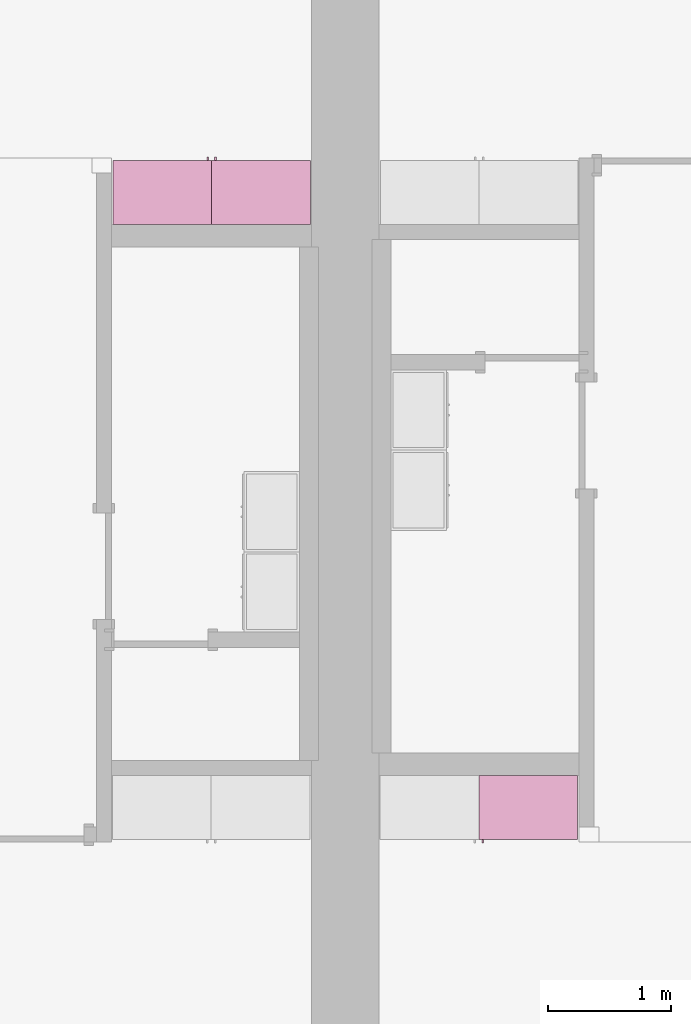
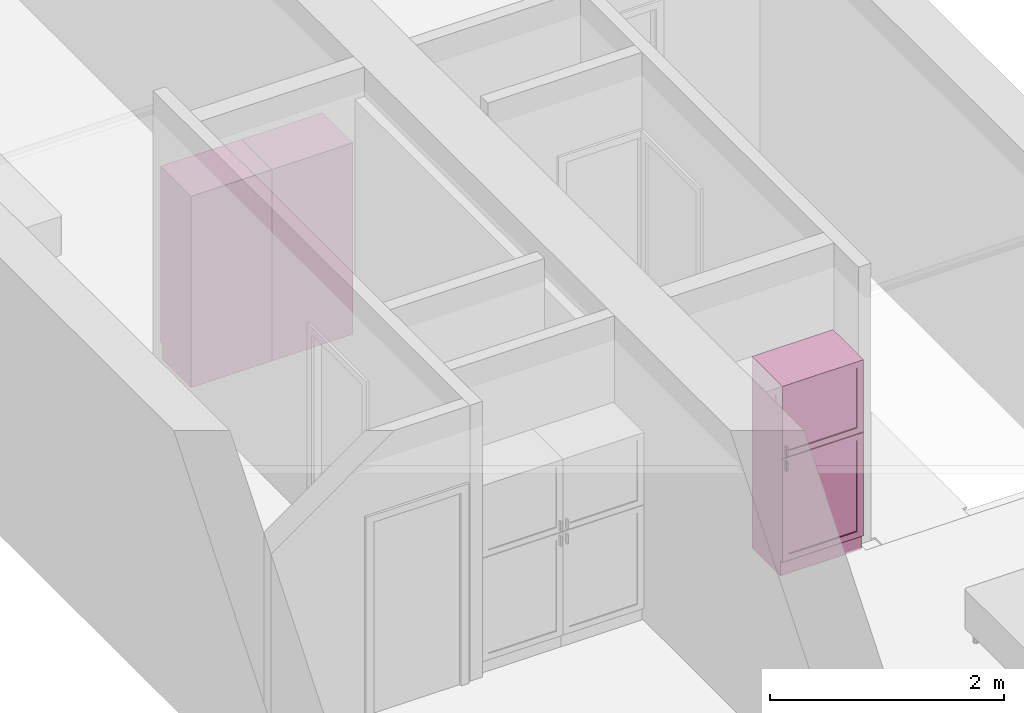
# One storey, part 15 of 16: 3 furnishings, 3 openings.
"""IFC2X3 building model written with IfcOpenShell, lengths in metres."""

import ifcopenshell
import ifcopenshell.guid

model = None  # the IFC model being written
_history = None  # IfcOwnerHistory: only IFC2X3 demands one
_inside = {}  # id of a spatial element -> (the spatial element, [elements in it])
_under = {}  # id of a project, library or spatial element -> (it, [spatial elements below it])
_declared = {}  # id of a project -> (the project, [libraries it declares])
_typed = {}  # id of a type object -> (the type object, [elements of that type])
_made_of = {}  # id of a material, layer set ... -> (it, [elements and type objects made of it])


def new_model(schema):
    """Start an empty IFC model of exactly this schema.

    Asked for "IFC4X3", IfcOpenShell would pick the latest addendum, in which some entities
    have other attributes; the version numbers below select the first issue.
    IFC2X3 requires an IfcOwnerHistory on every rooted entity: one is made here for all.
    """
    global model, _history
    if schema == "IFC4X3":
        model = ifcopenshell.file(schema_version=(4, 3, 0, 0))
    else:
        model = ifcopenshell.file(schema=schema)
    _inside.clear()
    _under.clear()
    _declared.clear()
    _typed.clear()
    _made_of.clear()
    _history = None
    if model.schema == "IFC2X3":
        org = make("IfcOrganization", Name="unknown")
        user = make(
            "IfcPersonAndOrganization",
            ThePerson=make("IfcPerson", FamilyName="unknown"),
            TheOrganization=org,
        )
        app = make(
            "IfcApplication",
            ApplicationDeveloper=org,
            Version="unknown",
            ApplicationFullName="unknown",
            ApplicationIdentifier="unknown",
        )
        _history = make(
            "IfcOwnerHistory",
            OwningUser=user,
            OwningApplication=app,
            ChangeAction="ADDED",
            CreationDate=0,
        )
    return model


def make(cls, **values):
    """One entity of the class cls with the attributes given. An attribute that is None is left unset."""
    return model.create_entity(
        cls, **{name: value for name, value in values.items() if value is not None}
    )


def entity(cls, *values):
    """Any entity or typed value of the class cls, its attributes in the order of the schema. None: left unset."""
    e = model.create_entity(cls)
    for i, value in enumerate(values):
        if value is not None:
            e[i] = value
    return e


def rooted(cls, **values):
    """An entity with a GlobalId (a new one), such as an element, a storey or a relation."""
    return make(cls, GlobalId=ifcopenshell.guid.new(), OwnerHistory=_history, **values)


def si_unit(unit_type, name, prefix=None):
    """IfcSIUnit, for example si_unit("LENGTHUNIT", "METRE", prefix="MILLI")."""
    return make("IfcSIUnit", UnitType=unit_type, Prefix=prefix, Name=name)


def converted_unit(unit_type, name, factor, base, dimensions=None, offset=None):
    """IfcConversionBasedUnit, such as the inch: factor (a typed value) times the base unit."""
    return make(
        "IfcConversionBasedUnit"
        if offset is None
        else "IfcConversionBasedUnitWithOffset",
        ConversionOffset=offset,
        Dimensions=None
        if dimensions is None
        else entity("IfcDimensionalExponents", *dimensions),
        UnitType=unit_type,
        Name=name,
        ConversionFactor=make(
            "IfcMeasureWithUnit", ValueComponent=factor, UnitComponent=base
        ),
    )


def assignment(units):
    """IfcUnitAssignment: the units of a project."""
    return None if units is None else make("IfcUnitAssignment", Units=units)


def point(xyz):
    """IfcCartesianPoint."""
    return None if xyz is None else make("IfcCartesianPoint", Coordinates=xyz)


def direction(xyz):
    """IfcDirection."""
    return None if xyz is None else make("IfcDirection", DirectionRatios=xyz)


def frame(location, z_axis=None, x_axis=None):
    """IfcAxis2Placement3D, a coordinate frame: its origin and axes. An axis left out is left unset."""
    return make(
        "IfcAxis2Placement3D",
        Location=point(location),
        Axis=direction(z_axis),
        RefDirection=direction(x_axis),
    )


def frame_2d(location, x_axis=None):
    """IfcAxis2Placement2D, a coordinate frame in the plane: its origin and x axis."""
    return make(
        "IfcAxis2Placement2D", Location=point(location), RefDirection=direction(x_axis)
    )


def origin():
    """The frame at (0, 0, 0) with its axes left unset."""
    return frame((0.0, 0.0, 0.0))


def origin_2d_with_axis():
    """The frame at (0, 0) in the plane with the x axis (1, 0) written out."""
    return frame_2d((0.0, 0.0), x_axis=(1.0, 0.0))


def place(relative_to, where):
    """IfcLocalPlacement: puts the frame where relative to a parent placement (None: the world)."""
    return make(
        "IfcLocalPlacement", PlacementRelTo=relative_to, RelativePlacement=where
    )


def context(
    kind, dimensions, precision=None, world=None, true_north=None, identifier=None
):
    """IfcGeometricRepresentationContext, for example the 3D "Model" context."""
    return make(
        "IfcGeometricRepresentationContext",
        ContextIdentifier=identifier,
        ContextType=kind,
        CoordinateSpaceDimension=dimensions,
        Precision=precision,
        WorldCoordinateSystem=world,
        TrueNorth=true_north,
    )


def project(units=None, contexts=None):
    """IfcProject with its units and contexts."""
    return rooted(
        "IfcProject",
        Name="project",
        RepresentationContexts=contexts,
        UnitsInContext=assignment(units),
    )


def spatial(cls, under=None, at=None, **own):
    """A site, building, storey or space (cls), placed at a placement, below another one or the project."""
    s = rooted(cls, ObjectPlacement=at, **own)
    if under is not None:
        _under.setdefault(under.id(), (under, []))[1].append(s)
    return s


def profile(cls, at=None, kind="AREA", **sizes):
    """A parametric profile (cls). Its sizes go by their IFC names, for example OverallWidth=200.0."""
    return make(cls, ProfileType=kind, Position=at, **sizes)


def rectangle(**sizes):
    """IfcRectangleProfileDef."""
    return profile("IfcRectangleProfileDef", **sizes)


def extrude(swept, where, along, depth):
    """IfcExtrudedAreaSolid: the profile swept, set in the frame where, extruded along a direction by depth."""
    return make(
        "IfcExtrudedAreaSolid",
        SweptArea=swept,
        Position=where,
        ExtrudedDirection=direction(along),
        Depth=depth,
    )


def faces_of(points, faces, orient=None, outer=None):
    """IfcFace entities. A face is a list of loops; a loop is a list of indices into points, from 0.

    orient and outer hold one flag for each loop. By default every Orientation is true, the
    first loop of a face is its IfcFaceOuterBound and the others are IfcFaceBound.
    """
    made = []
    for i, loops in enumerate(faces):
        bounds = []
        for j, loop in enumerate(loops):
            is_outer = j == 0 if outer is None else outer[i][j]
            bounds.append(
                make(
                    "IfcFaceOuterBound" if is_outer else "IfcFaceBound",
                    Bound=make("IfcPolyLoop", Polygon=[points[k] for k in loop]),
                    Orientation=True if orient is None else orient[i][j],
                )
            )
        made.append(make("IfcFace", Bounds=bounds))
    return made


def face_set(faces, orient=None, outer=None):
    """The faces of one IfcConnectedFaceSet. surface_model builds it on its shared points."""
    return ("IfcConnectedFaceSet", faces, orient, outer)


def surface_model(cls, points, shells):
    """IfcFaceBasedSurfaceModel or IfcShellBasedSurfaceModel (cls): surfaces that need not close."""
    shared = [point(p) for p in points]
    made = [make(c, CfsFaces=faces_of(shared, fs, o, b)) for c, fs, o, b in shells]
    if cls == "IfcFaceBasedSurfaceModel":
        return make(cls, FbsmFaces=made)
    return make(cls, SbsmBoundary=made)


def shape(context_of_items, identifier, shape_type, items):
    """IfcShapeRepresentation: the items that make up one representation, for example the "Body"."""
    return make(
        "IfcShapeRepresentation",
        ContextOfItems=context_of_items,
        RepresentationIdentifier=identifier,
        RepresentationType=shape_type,
        Items=items,
    )


def source(mapping_origin, context_of_items, identifier, shape_type, items):
    """IfcRepresentationMap: a shape defined once, which mapped items show again and again."""
    return make(
        "IfcRepresentationMap",
        MappingOrigin=mapping_origin,
        MappedRepresentation=shape(context_of_items, identifier, shape_type, items),
    )


def transform(
    local_origin,
    x_axis=None,
    y_axis=None,
    z_axis=None,
    scale=None,
    scale2=None,
    scale3=None,
    uniform=True,
):
    """IfcCartesianTransformationOperator3D, or its non-uniform kind. x_axis, y_axis, z_axis: its Axis1, 2, 3."""
    if uniform:
        return make(
            "IfcCartesianTransformationOperator3D",
            Axis1=direction(x_axis),
            Axis2=direction(y_axis),
            LocalOrigin=point(local_origin),
            Scale=scale,
            Axis3=direction(z_axis),
        )
    return make(
        "IfcCartesianTransformationOperator3DnonUniform",
        Axis1=direction(x_axis),
        Axis2=direction(y_axis),
        LocalOrigin=point(local_origin),
        Scale=scale,
        Axis3=direction(z_axis),
        Scale2=scale2,
        Scale3=scale3,
    )


def mapped(mapping_source, mapping_target):
    """IfcMappedItem: shows the shape of a source again, moved by a transform."""
    return make(
        "IfcMappedItem", MappingSource=mapping_source, MappingTarget=mapping_target
    )


def made_of(thing, what):
    """Note that an element or type object is made of a material, layer set ...; save() writes the relation."""
    if what is not None:
        _made_of.setdefault(what.id(), (what, []))[1].append(thing)
    return thing


def type_object(cls, material=None, **own):
    """A type object (cls), such as IfcWallType, which elements share."""
    return made_of(rooted(cls, **own), material)


def type_shapes(of_type, sources):
    """Give a type object the sources (RepresentationMaps) that its elements show as mapped items."""
    of_type.RepresentationMaps = sources


def element(
    cls,
    number,
    at=None,
    inside=None,
    cuts=None,
    type_object=None,
    material=None,
    context=None,
    identifier="Body",
    shape_type=None,
    held_by="IfcProductDefinitionShape",
    body=None,
    shapes=None,
    **own,
):
    """One element of the class cls, such as IfcWall. Its Tag is "e" and its number.

    at: its placement. inside: the storey or other place that contains it. cuts: it is an
    opening in that element (IfcRelVoidsElement). A single representation is given by context,
    identifier, shape_type and body (its items); several are given by shapes. held_by: the class
    of the entity that holds the representations. save() writes the other relations.
    """
    e = rooted(cls, Tag="e%d" % number, ObjectPlacement=at, **own)
    if body is not None:
        shapes = [shape(context, identifier, shape_type, body)]
    if shapes is not None:
        e.Representation = make(held_by, Representations=shapes)
    if inside is not None:
        _inside.setdefault(inside.id(), (inside, []))[1].append(e)
    if cuts is not None:
        rooted(
            "IfcRelVoidsElement", RelatingBuildingElement=cuts, RelatedOpeningElement=e
        )
    if type_object is not None:
        _typed.setdefault(type_object.id(), (type_object, []))[1].append(e)
    return made_of(e, material)


def aggregate(whole, parts):
    """IfcRelAggregates: a whole, such as a stair, and the parts it consists of."""
    return rooted("IfcRelAggregates", RelatingObject=whole, RelatedObjects=parts)


def save(model, path):
    """Write the relations noted so far, then the file.

    IfcRelAggregates (storeys below a building ...), IfcRelContainedInSpatialStructure (elements
    in a storey), IfcRelDefinesByType, IfcRelAssociatesMaterial and IfcRelDeclares: one each for
    every whole, place, type object, material and project.
    """
    for whole, parts in _under.values():
        aggregate(whole, parts)
    for where, things in _inside.values():
        rooted(
            "IfcRelContainedInSpatialStructure",
            RelatedElements=things,
            RelatingStructure=where,
        )
    for kind, things in _typed.values():
        rooted("IfcRelDefinesByType", RelatedObjects=things, RelatingType=kind)
    for what, things in _made_of.values():
        rooted("IfcRelAssociatesMaterial", RelatedObjects=things, RelatingMaterial=what)
    for by, libraries in _declared.values():
        rooted("IfcRelDeclares", RelatingContext=by, RelatedDefinitions=libraries)
    model.write(path)


model = new_model("IFC2X3")

# Units and contexts
model_context = context("Model", 3, precision=1e-09, world=origin())
plan_context = context("Plan", 3, precision=1e-09, world=origin())
ifc_project = project(units=[si_unit("LENGTHUNIT", "METRE"), si_unit("AREAUNIT", "SQUARE_METRE"), si_unit("VOLUMEUNIT", "CUBIC_METRE"), converted_unit("PLANEANGLEUNIT", "DEGREE", entity("IfcRatioMeasure", 0.01745329251994328), si_unit("PLANEANGLEUNIT", "RADIAN"), dimensions=[0, 0, 0, 0, 0, 0, 0]), si_unit("TIMEUNIT", "SECOND")], contexts=[model_context, plan_context])

# Site, building, storey, space
site_placement = place(None, origin())
site = spatial("IfcSite", under=ifc_project, at=site_placement, CompositionType="ELEMENT")
building_placement = place(site_placement, origin())
building = spatial("IfcBuilding", under=site, at=building_placement, CompositionType="ELEMENT")
storey_placement = place(building_placement, frame((0.0, 0.0, 3.100000000000196)))
storey = spatial("IfcBuildingStorey", under=building, at=storey_placement, Name="Level 2", CompositionType="ELEMENT", Elevation=3.100000000000196)
space_1_placement = place(storey_placement, origin())
space_1 = spatial("IfcSpace", under=storey, at=space_1_placement, CompositionType="ELEMENT", InteriorOrExteriorSpace="INTERNAL")

# Furnishing, opening
furniture_type_1 = type_object("IfcFurnitureType", Name="800 mm", AssemblyPlace="NOTDEFINED")
shared_shape_1 = source(origin(), model_context, "Body", "SurfaceModel", [
    surface_model("IfcFaceBasedSurfaceModel", [(0.7999999999999998, 0.5009500000000022, 0.1615874999998423), (0.7999999999999998, 0.5009500000000022, 2.0), (0.0, 0.5009499999999997, 2.0), (0.0, 0.5009499999999997, 0.1615874999998423), (0.7809499999999974, 0.5009500000000022, 1.980949999999954), (0.7809499999999974, 0.5009500000000022, 0.1806374999998428), (0.01904999999999817, 0.5009499999999997, 0.1806374999998428), (0.01904999999999817, 0.5009499999999997, 1.980949999999954), (0.0, 0.0, 2.0), (0.0, 0.0, 0.0), (0.8000000000000026, 0.0, 0.0), (0.8000000000000014, 0.0, 2.0), (0.780949999999999, 0.0, 1.980949999999954), (0.780949999999999, 0.0, 0.1806374999998428), (0.0190499999999998, 0.0, 0.1806374999998427), (0.0190499999999998, 0.0, 1.980949999999954), (0.8000000000000026, 0.4850000000000004, 0.0), (0.7999999999999999, 0.4850000000000004, 0.1615874999998318), (0.0, 0.4850000000000004, 0.0), (0.0, 0.4850000000000004, 0.1615874999998423), (0.7745999999999997, 0.5454000000000022, 1.371548036695815), (0.7620677683693553, 0.5454000000000021, 1.371548036695815), (0.7620677683693553, 0.5454000000000021, 1.269948036695815), (0.7745999999999997, 0.5454000000000022, 1.269948036695815), (0.7745999999999988, 0.5454000000000022, 1.219148036695816), (0.7620677683693542, 0.5454000000000021, 1.219148036695816), (0.7620677683693542, 0.5454000000000021, 1.117548036695818), (0.7745999999999988, 0.5454000000000022, 1.117548036695818), (0.7745999999999998, 0.5200000000000022, 1.371548036695815), (0.7620677683693555, 0.5200000000000021, 1.371548036695815), (0.7620677683693555, 0.5200000000000021, 1.269948036695815), (0.7745999999999998, 0.5200000000000022, 1.269948036695815), (0.7745999999999988, 0.5200000000000022, 1.219148036695816), (0.7620677683693542, 0.5200000000000021, 1.219148036695816), (0.7620677683693542, 0.5200000000000021, 1.117548036695818), (0.7745999999999988, 0.5200000000000022, 1.117548036695818), (0.7364999999999996, 0.5073000000000021, 1.936499999999956), (0.06350000000000126, 0.5072999999999999, 1.936499999999956), (0.06350000000000126, 0.5072999999999999, 1.308048036695816), (0.7364999999999996, 0.5073000000000021, 1.308048036695816), (0.736499999999999, 0.5073000000000021, 1.181048036695814), (0.06350000000000072, 0.5072999999999999, 1.181048036695814), (0.06350000000000072, 0.5072999999999999, 0.2250874999998395), (0.736499999999999, 0.5073000000000021, 0.2250874999998395), (0.7364999999999996, 0.5009500000000021, 1.936499999999956), (0.06350000000000126, 0.5009499999999999, 1.936499999999956), (0.06350000000000126, 0.5009499999999999, 1.308048036695816), (0.7364999999999996, 0.5009500000000021, 1.308048036695816), (0.736499999999999, 0.5009500000000021, 1.181048036695814), (0.06350000000000072, 0.5009499999999999, 1.181048036695814), (0.06350000000000072, 0.5009499999999999, 0.2250874999998395), (0.736499999999999, 0.5009500000000021, 0.2250874999998395), (0.8, 0.5200000000000023, 2.0), (0.0, 0.5199999999999997, 2.0), (0.0, 0.5199999999999997, 1.247723036695813), (0.8, 0.5200000000000023, 1.247723036695813), (0.7364999999999996, 0.5200000000000021, 1.936499999999956), (0.7364999999999996, 0.5200000000000021, 1.308048036695816), (0.0635000000000012, 0.5199999999999999, 1.308048036695816), (0.0635000000000012, 0.5199999999999999, 1.936499999999956), (0.7999999999999998, 0.5200000000000023, 0.1615874999998214), (0.7999999999999998, 0.5200000000000023, 1.241373036695815), (0.0, 0.5199999999999997, 1.241373036695815), (0.0, 0.5199999999999997, 0.1615874999998214), (0.736499999999999, 0.5200000000000021, 1.181048036695817), (0.736499999999999, 0.5200000000000021, 0.2250874999998395), (0.06350000000000065, 0.5199999999999999, 0.2250874999998395), (0.06350000000000065, 0.5199999999999999, 1.181048036695817), (0.8000000000000002, 0.5009500000000023, 2.0), (0.0, 0.5009499999999997, 2.0), (0.0, 0.5009499999999997, 1.247723036695813), (0.8, 0.5009500000000023, 1.247723036695813), (0.7364999999999996, 0.5009500000000021, 1.936499999999956), (0.7364999999999996, 0.5009500000000021, 1.308048036695816), (0.06350000000000126, 0.5009499999999999, 1.308048036695816), (0.06350000000000126, 0.5009499999999999, 1.936499999999956), (0.7999999999999999, 0.5009500000000023, 0.1615874999998214), (0.7999999999999999, 0.5009500000000023, 1.241373036695815), (0.0, 0.5009499999999997, 1.241373036695815), (0.0, 0.5009499999999997, 0.1615874999998214), (0.736499999999999, 0.5009500000000021, 1.181048036695817), (0.736499999999999, 0.5009500000000021, 0.2250874999998395), (0.06350000000000072, 0.5009499999999999, 0.2250874999998395), (0.06350000000000072, 0.5009499999999999, 1.181048036695817), (0.7809499999999987, 0.01905000000000129, 1.980949999999952), (0.0190499999999998, 0.01905000000000129, 1.980949999999952), (0.0190499999999998, 0.01905000000000129, 0.1806374999998463), (0.7809499999999987, 0.01905000000000129, 0.1806374999998463), (0.7809499999999987, 0.0, 1.980949999999952), (0.0190499999999998, 0.0, 1.980949999999952), (0.01904999999999987, 0.0, 0.1806374999998463), (0.7809499999999988, 0.0, 0.1806374999998463)], [face_set([[[0, 1, 2, 3], [4, 5, 6, 7]], [[8, 9, 10, 11], [12, 13, 14, 15]], [[1, 11, 10, 16, 17, 0]], [[2, 1, 11, 8]], [[3, 2, 8, 9, 18, 19]], [[0, 17, 19, 3]], [[5, 4, 12, 13]], [[6, 5, 13, 14]], [[7, 6, 14, 15]], [[4, 12, 15, 7]], [[10, 9, 18, 16]], [[18, 16, 17, 19]]]), face_set([[[20, 21, 22, 23]], [[24, 25, 26, 27]], [[28, 29, 30, 31]], [[32, 33, 34, 35]], [[21, 20, 28, 29]], [[22, 30, 29, 21]], [[23, 31, 30, 22]], [[20, 23, 31, 28]], [[25, 24, 32, 33]], [[26, 34, 33, 25]], [[27, 35, 34, 26]], [[24, 27, 35, 32]]]), face_set([[[36, 37, 38, 39]], [[40, 41, 42, 43]], [[44, 45, 46, 47]], [[48, 49, 50, 51]], [[37, 36, 44, 45]], [[38, 37, 45, 46]], [[39, 47, 46, 38]], [[36, 44, 47, 39]], [[41, 40, 48, 49]], [[42, 41, 49, 50]], [[43, 51, 50, 42]], [[40, 48, 51, 43]]]), face_set([[[52, 53, 54, 55], [56, 57, 58, 59]], [[60, 61, 62, 63], [64, 65, 66, 67]], [[68, 69, 70, 71], [72, 73, 74, 75]], [[76, 77, 78, 79], [80, 81, 82, 83]], [[53, 52, 68, 69]], [[54, 70, 69, 53]], [[55, 71, 70, 54]], [[52, 68, 71, 55]], [[61, 77, 76, 60]], [[62, 61, 77, 78]], [[63, 79, 78, 62]], [[60, 76, 79, 63]], [[57, 56, 72, 73]], [[58, 57, 73, 74]], [[59, 75, 74, 58]], [[56, 72, 75, 59]], [[65, 64, 80, 81]], [[66, 65, 81, 82]], [[67, 83, 82, 66]], [[64, 80, 83, 67]]]), face_set([[[84, 85, 86, 87]], [[88, 89, 90, 91]], [[85, 84, 88, 89]], [[86, 90, 89, 85]], [[87, 91, 90, 86]], [[84, 88, 91, 87]]])]),
])
type_shapes(furniture_type_1, [shared_shape_1])
furnishing_1_placement = place(space_1_placement, frame((6.282999999999985, -11.13400000000001, 0.0), z_axis=(0.0, 0.0, 1.0), x_axis=(-1.0, 0.0, 0.0)))
furnishing_1 = element("IfcFurnishingElement", 1, at=furnishing_1_placement, inside=space_1, type_object=furniture_type_1, ObjectType="800 mm", context=model_context, shape_type="MappedRepresentation", body=[
    mapped(shared_shape_1, transform((0.0, 0.0, 0.0), scale=1.0)),
])
opening_1_placement = place(space_1_placement, frame((6.282999999999985, -11.13400000000001, 0.0), z_axis=(0.0, 0.0, 1.0), x_axis=(-1.0, 0.0, 0.0)))
element("IfcOpeningElement", 2, at=opening_1_placement, cuts=furnishing_1, ObjectType="Opening", context=model_context, shape_type="SweptSolid", body=[
    extrude(rectangle(XDim=1.800312500000111, YDim=0.7618999999999992, at=origin_2d_with_axis()), frame((-0.01873770491802511, 0.0, -2.019206250000297), z_axis=(0.0, -1.0, 0.0), x_axis=(0.0, 0.0, -1.0)), (0.0, 0.0, 1.0), 0.5009499999999997),
])

# Space
space_2_placement = place(storey_placement, origin())
space_2 = spatial("IfcSpace", under=storey, at=space_2_placement, CompositionType="ELEMENT", InteriorOrExteriorSpace="INTERNAL")

# Furnishing, opening
furniture_type_2 = type_object("IfcFurnitureType", Name="800 mm", AssemblyPlace="NOTDEFINED")
shared_shape_2 = source(origin(), model_context, "Body", "SurfaceModel", [
    surface_model("IfcFaceBasedSurfaceModel", [(0.7999999999999998, 0.04444999999999991, 0.1615874999998423), (0.0, 0.04445000000000255, 0.1615874999998423), (0.0, 0.04445000000000255, 2.0), (0.7999999999999998, 0.04444999999999991, 2.0), (0.7809499999999974, 0.04444999999999998, 1.980949999999954), (0.01904999999999817, 0.04445000000000248, 1.980949999999954), (0.01904999999999817, 0.04445000000000248, 0.1806374999998427), (0.7809499999999974, 0.04444999999999998, 0.1806374999998428), (0.0, 0.5454000000000022, 2.0), (0.8000000000000014, 0.5453999999999996, 2.0), (0.8000000000000026, 0.5453999999999996, 0.0), (0.0, 0.5454000000000009, 0.0), (0.780949999999999, 0.5453999999999996, 1.980949999999954), (0.0190499999999998, 0.5454000000000021, 1.980949999999954), (0.0190499999999998, 0.5454000000000021, 0.1806374999998428), (0.780949999999999, 0.5453999999999996, 0.1806374999998428), (0.7999999999999999, 0.06040000000000177, 0.1615874999998423), (0.7999999999999999, 0.06040000000000177, 0.0), (0.0, 0.06040000000000177, 0.0), (0.0, 0.06040000000000177, 0.1615874999998318), (0.7745999999999997, 0.0, 1.371548036695815), (0.7745999999999997, 0.0, 1.269948036695815), (0.7620677683693553, 0.0, 1.269948036695815), (0.7620677683693553, 0.0, 1.371548036695815), (0.7745999999999988, 0.0, 1.219148036695816), (0.7745999999999988, 0.0, 1.117548036695818), (0.7620677683693542, 0.0, 1.117548036695818), (0.7620677683693542, 0.0, 1.219148036695816), (0.7745999999999998, 0.02539999999999998, 1.371548036695815), (0.7745999999999998, 0.02539999999999998, 1.269948036695815), (0.7620677683693555, 0.02540000000000005, 1.269948036695815), (0.7620677683693555, 0.02540000000000005, 1.371548036695815), (0.7745999999999988, 0.02539999999999998, 1.219148036695816), (0.7745999999999988, 0.02539999999999998, 1.117548036695818), (0.7620677683693542, 0.02540000000000005, 1.117548036695818), (0.7620677683693542, 0.02540000000000005, 1.219148036695816), (0.7364999999999996, 0.03810000000000007, 1.936499999999956), (0.7364999999999996, 0.03810000000000007, 1.308048036695816), (0.06350000000000126, 0.03810000000000231, 1.308048036695816), (0.06350000000000126, 0.03810000000000231, 1.936499999999956), (0.736499999999999, 0.03810000000000007, 1.181048036695814), (0.736499999999999, 0.03810000000000007, 0.2250874999998395), (0.06350000000000072, 0.03810000000000231, 0.2250874999998395), (0.06350000000000072, 0.03810000000000231, 1.181048036695814), (0.7364999999999996, 0.04445000000000005, 1.936499999999956), (0.7364999999999996, 0.04445000000000005, 1.308048036695816), (0.06350000000000126, 0.04445000000000228, 1.308048036695816), (0.06350000000000126, 0.04445000000000228, 1.936499999999956), (0.736499999999999, 0.04445000000000005, 1.181048036695814), (0.736499999999999, 0.04445000000000005, 0.2250874999998395), (0.06350000000000072, 0.04445000000000228, 0.2250874999998395), (0.06350000000000072, 0.04445000000000228, 1.181048036695814), (0.8, 0.02539999999999984, 2.0), (0.8, 0.02539999999999984, 1.247723036695813), (0.0, 0.02540000000000248, 1.247723036695813), (0.0, 0.02540000000000248, 2.0), (0.7364999999999996, 0.02540000000000005, 1.936499999999956), (0.0635000000000012, 0.02540000000000228, 1.936499999999956), (0.0635000000000012, 0.02540000000000228, 1.308048036695816), (0.7364999999999996, 0.02540000000000005, 1.308048036695816), (0.7999999999999998, 0.02539999999999984, 0.1615874999998214), (0.0, 0.02540000000000248, 0.1615874999998214), (0.0, 0.02540000000000248, 1.241373036695815), (0.7999999999999998, 0.02539999999999984, 1.241373036695815), (0.736499999999999, 0.02540000000000005, 1.181048036695817), (0.06350000000000065, 0.02540000000000228, 1.181048036695817), (0.06350000000000065, 0.02540000000000228, 0.2250874999998395), (0.736499999999999, 0.02540000000000005, 0.2250874999998395), (0.8000000000000002, 0.04444999999999984, 2.0), (0.8000000000000002, 0.04444999999999984, 1.247723036695813), (0.0, 0.04445000000000248, 1.247723036695813), (0.0, 0.04445000000000248, 2.0), (0.7364999999999996, 0.04445000000000005, 1.936499999999956), (0.06350000000000126, 0.04445000000000228, 1.936499999999956), (0.06350000000000126, 0.04445000000000228, 1.308048036695816), (0.7364999999999996, 0.04445000000000005, 1.308048036695816), (0.7999999999999999, 0.04444999999999984, 0.1615874999998214), (0.0, 0.04445000000000248, 0.1615874999998214), (0.0, 0.04445000000000248, 1.241373036695815), (0.7999999999999999, 0.04444999999999984, 1.241373036695815), (0.736499999999999, 0.04445000000000005, 1.181048036695817), (0.06350000000000072, 0.04445000000000228, 1.181048036695817), (0.06350000000000072, 0.04445000000000228, 0.2250874999998395), (0.736499999999999, 0.04445000000000005, 0.2250874999998395), (0.7809499999999987, 0.5263500000000009, 1.980949999999952), (0.7809499999999988, 0.5263500000000009, 0.1806374999998463), (0.01904999999999987, 0.5263500000000009, 0.1806374999998463), (0.0190499999999998, 0.5263500000000009, 1.980949999999952), (0.7809499999999987, 0.5454000000000009, 1.980949999999952), (0.7809499999999987, 0.5454000000000009, 0.1806374999998463), (0.0190499999999998, 0.5454000000000009, 0.1806374999998463), (0.0190499999999998, 0.5454000000000009, 1.980949999999952)], [face_set([[[0, 1, 2, 3], [4, 5, 6, 7]], [[8, 9, 10, 11], [12, 13, 14, 15]], [[3, 0, 16, 17, 10, 9]], [[2, 8, 9, 3]], [[1, 2, 8, 11, 18, 19]], [[0, 1, 19, 16]], [[7, 15, 12, 4]], [[6, 14, 15, 7]], [[5, 13, 14, 6]], [[4, 5, 13, 12]], [[10, 17, 18, 11]], [[18, 19, 16, 17]]]), face_set([[[20, 21, 22, 23]], [[24, 25, 26, 27]], [[28, 29, 30, 31]], [[32, 33, 34, 35]], [[23, 31, 28, 20]], [[22, 23, 31, 30]], [[21, 22, 30, 29]], [[20, 28, 29, 21]], [[27, 35, 32, 24]], [[26, 27, 35, 34]], [[25, 26, 34, 33]], [[24, 32, 33, 25]]]), face_set([[[36, 37, 38, 39]], [[40, 41, 42, 43]], [[44, 45, 46, 47]], [[48, 49, 50, 51]], [[39, 47, 44, 36]], [[38, 46, 47, 39]], [[37, 38, 46, 45]], [[36, 37, 45, 44]], [[43, 51, 48, 40]], [[42, 50, 51, 43]], [[41, 42, 50, 49]], [[40, 41, 49, 48]]]), face_set([[[52, 53, 54, 55], [56, 57, 58, 59]], [[60, 61, 62, 63], [64, 65, 66, 67]], [[68, 69, 70, 71], [72, 73, 74, 75]], [[76, 77, 78, 79], [80, 81, 82, 83]], [[55, 71, 68, 52]], [[54, 55, 71, 70]], [[53, 54, 70, 69]], [[52, 53, 69, 68]], [[63, 60, 76, 79]], [[62, 78, 79, 63]], [[61, 62, 78, 77]], [[60, 61, 77, 76]], [[59, 75, 72, 56]], [[58, 74, 75, 59]], [[57, 58, 74, 73]], [[56, 57, 73, 72]], [[67, 83, 80, 64]], [[66, 82, 83, 67]], [[65, 66, 82, 81]], [[64, 65, 81, 80]]]), face_set([[[84, 85, 86, 87]], [[88, 89, 90, 91]], [[87, 91, 88, 84]], [[86, 87, 91, 90]], [[85, 86, 90, 89]], [[84, 85, 89, 88]]])]),
])
type_shapes(furniture_type_2, [shared_shape_2])
furnishing_2_placement = place(space_2_placement, frame((4.116999999999995, -6.120600000000001, 0.0), z_axis=(0.0, 0.0, 1.0), x_axis=(-1.0, 0.0, 0.0)))
furnishing_2 = element("IfcFurnishingElement", 3, at=furnishing_2_placement, inside=space_2, type_object=furniture_type_2, ObjectType="800 mm", context=model_context, shape_type="MappedRepresentation", body=[
    mapped(shared_shape_2, transform((0.0, 0.0, 0.0), scale=1.0)),
])
opening_2_placement = place(space_2_placement, frame((4.116999999999995, -6.120600000000001, 0.0), z_axis=(0.0, 0.0, 1.0), x_axis=(-1.0, 0.0, 0.0)))
element("IfcOpeningElement", 4, at=opening_2_placement, cuts=furnishing_2, ObjectType="Opening", context=model_context, shape_type="SweptSolid", body=[
    extrude(rectangle(XDim=1.800312500000111, YDim=0.7618999999999992, at=frame_2d((0.0, 0.0), x_axis=(0.0, 1.0))), frame((-0.01873770491802511, 0.0, -2.019206250000297), z_axis=(0.0, 1.0, 0.0), x_axis=(1.0, 0.0, 0.0)), (0.0, 0.0, 1.0), 0.5009499999999997),
])

furniture_type_3 = type_object("IfcFurnitureType", Name="800 mm", AssemblyPlace="NOTDEFINED")
shared_shape_3 = source(origin(), model_context, "Body", "SurfaceModel", [
    surface_model("IfcFaceBasedSurfaceModel", [(0.7999999999999998, 0.5009500000000022, 0.1615874999998423), (0.7999999999999998, 0.5009500000000022, 2.0), (0.0, 0.5009499999999997, 2.0), (0.0, 0.5009499999999997, 0.1615874999998423), (0.7809499999999974, 0.5009500000000022, 1.980949999999954), (0.7809499999999974, 0.5009500000000022, 0.1806374999998428), (0.01904999999999817, 0.5009499999999997, 0.1806374999998428), (0.01904999999999817, 0.5009499999999997, 1.980949999999954), (0.0, 0.0, 2.0), (0.0, 0.0, 0.0), (0.8000000000000026, 0.0, 0.0), (0.8000000000000014, 0.0, 2.0), (0.780949999999999, 0.0, 1.980949999999954), (0.780949999999999, 0.0, 0.1806374999998428), (0.0190499999999998, 0.0, 0.1806374999998427), (0.0190499999999998, 0.0, 1.980949999999954), (0.8000000000000026, 0.4850000000000004, 0.0), (0.7999999999999999, 0.4850000000000004, 0.1615874999998318), (0.0, 0.4850000000000004, 0.0), (0.0, 0.4850000000000004, 0.1615874999998423), (0.7745999999999997, 0.5454000000000022, 1.371548036695815), (0.7620677683693553, 0.5454000000000021, 1.371548036695815), (0.7620677683693553, 0.5454000000000021, 1.269948036695815), (0.7745999999999997, 0.5454000000000022, 1.269948036695815), (0.7745999999999988, 0.5454000000000022, 1.219148036695816), (0.7620677683693542, 0.5454000000000021, 1.219148036695816), (0.7620677683693542, 0.5454000000000021, 1.117548036695818), (0.7745999999999988, 0.5454000000000022, 1.117548036695818), (0.7745999999999998, 0.5200000000000022, 1.371548036695815), (0.7620677683693555, 0.5200000000000021, 1.371548036695815), (0.7620677683693555, 0.5200000000000021, 1.269948036695815), (0.7745999999999998, 0.5200000000000022, 1.269948036695815), (0.7745999999999988, 0.5200000000000022, 1.219148036695816), (0.7620677683693542, 0.5200000000000021, 1.219148036695816), (0.7620677683693542, 0.5200000000000021, 1.117548036695818), (0.7745999999999988, 0.5200000000000022, 1.117548036695818), (0.7364999999999996, 0.5073000000000021, 1.936499999999956), (0.06350000000000126, 0.5072999999999999, 1.936499999999956), (0.06350000000000126, 0.5072999999999999, 1.308048036695816), (0.7364999999999996, 0.5073000000000021, 1.308048036695816), (0.736499999999999, 0.5073000000000021, 1.181048036695814), (0.06350000000000072, 0.5072999999999999, 1.181048036695814), (0.06350000000000072, 0.5072999999999999, 0.2250874999998395), (0.736499999999999, 0.5073000000000021, 0.2250874999998395), (0.7364999999999996, 0.5009500000000021, 1.936499999999956), (0.06350000000000126, 0.5009499999999999, 1.936499999999956), (0.06350000000000126, 0.5009499999999999, 1.308048036695816), (0.7364999999999996, 0.5009500000000021, 1.308048036695816), (0.736499999999999, 0.5009500000000021, 1.181048036695814), (0.06350000000000072, 0.5009499999999999, 1.181048036695814), (0.06350000000000072, 0.5009499999999999, 0.2250874999998395), (0.736499999999999, 0.5009500000000021, 0.2250874999998395), (0.8, 0.5200000000000023, 2.0), (0.0, 0.5199999999999997, 2.0), (0.0, 0.5199999999999997, 1.247723036695813), (0.8, 0.5200000000000023, 1.247723036695813), (0.7364999999999996, 0.5200000000000021, 1.936499999999956), (0.7364999999999996, 0.5200000000000021, 1.308048036695816), (0.0635000000000012, 0.5199999999999999, 1.308048036695816), (0.0635000000000012, 0.5199999999999999, 1.936499999999956), (0.7999999999999998, 0.5200000000000023, 0.1615874999998214), (0.7999999999999998, 0.5200000000000023, 1.241373036695815), (0.0, 0.5199999999999997, 1.241373036695815), (0.0, 0.5199999999999997, 0.1615874999998214), (0.736499999999999, 0.5200000000000021, 1.181048036695817), (0.736499999999999, 0.5200000000000021, 0.2250874999998395), (0.06350000000000065, 0.5199999999999999, 0.2250874999998395), (0.06350000000000065, 0.5199999999999999, 1.181048036695817), (0.8000000000000002, 0.5009500000000023, 2.0), (0.0, 0.5009499999999997, 2.0), (0.0, 0.5009499999999997, 1.247723036695813), (0.8, 0.5009500000000023, 1.247723036695813), (0.7364999999999996, 0.5009500000000021, 1.936499999999956), (0.7364999999999996, 0.5009500000000021, 1.308048036695816), (0.06350000000000126, 0.5009499999999999, 1.308048036695816), (0.06350000000000126, 0.5009499999999999, 1.936499999999956), (0.7999999999999999, 0.5009500000000023, 0.1615874999998214), (0.7999999999999999, 0.5009500000000023, 1.241373036695815), (0.0, 0.5009499999999997, 1.241373036695815), (0.0, 0.5009499999999997, 0.1615874999998214), (0.736499999999999, 0.5009500000000021, 1.181048036695817), (0.736499999999999, 0.5009500000000021, 0.2250874999998395), (0.06350000000000072, 0.5009499999999999, 0.2250874999998395), (0.06350000000000072, 0.5009499999999999, 1.181048036695817), (0.7809499999999987, 0.01905000000000129, 1.980949999999952), (0.0190499999999998, 0.01905000000000129, 1.980949999999952), (0.0190499999999998, 0.01905000000000129, 0.1806374999998463), (0.7809499999999987, 0.01905000000000129, 0.1806374999998463), (0.7809499999999987, 0.0, 1.980949999999952), (0.0190499999999998, 0.0, 1.980949999999952), (0.01904999999999987, 0.0, 0.1806374999998463), (0.7809499999999988, 0.0, 0.1806374999998463)], [face_set([[[0, 1, 2, 3], [4, 5, 6, 7]], [[8, 9, 10, 11], [12, 13, 14, 15]], [[1, 11, 10, 16, 17, 0]], [[2, 1, 11, 8]], [[3, 2, 8, 9, 18, 19]], [[0, 17, 19, 3]], [[5, 4, 12, 13]], [[6, 5, 13, 14]], [[7, 6, 14, 15]], [[4, 12, 15, 7]], [[10, 9, 18, 16]], [[18, 16, 17, 19]]]), face_set([[[20, 21, 22, 23]], [[24, 25, 26, 27]], [[28, 29, 30, 31]], [[32, 33, 34, 35]], [[21, 20, 28, 29]], [[22, 30, 29, 21]], [[23, 31, 30, 22]], [[20, 23, 31, 28]], [[25, 24, 32, 33]], [[26, 34, 33, 25]], [[27, 35, 34, 26]], [[24, 27, 35, 32]]]), face_set([[[36, 37, 38, 39]], [[40, 41, 42, 43]], [[44, 45, 46, 47]], [[48, 49, 50, 51]], [[37, 36, 44, 45]], [[38, 37, 45, 46]], [[39, 47, 46, 38]], [[36, 44, 47, 39]], [[41, 40, 48, 49]], [[42, 41, 49, 50]], [[43, 51, 50, 42]], [[40, 48, 51, 43]]]), face_set([[[52, 53, 54, 55], [56, 57, 58, 59]], [[60, 61, 62, 63], [64, 65, 66, 67]], [[68, 69, 70, 71], [72, 73, 74, 75]], [[76, 77, 78, 79], [80, 81, 82, 83]], [[53, 52, 68, 69]], [[54, 70, 69, 53]], [[55, 71, 70, 54]], [[52, 68, 71, 55]], [[61, 77, 76, 60]], [[62, 61, 77, 78]], [[63, 79, 78, 62]], [[60, 76, 79, 63]], [[57, 56, 72, 73]], [[58, 57, 73, 74]], [[59, 75, 74, 58]], [[56, 72, 75, 59]], [[65, 64, 80, 81]], [[66, 65, 81, 82]], [[67, 83, 82, 66]], [[64, 80, 83, 67]]]), face_set([[[84, 85, 86, 87]], [[88, 89, 90, 91]], [[85, 84, 88, 89]], [[86, 90, 89, 85]], [[87, 91, 90, 86]], [[84, 88, 91, 87]]])]),
])
type_shapes(furniture_type_3, [shared_shape_3])
furnishing_3_placement = place(space_2_placement, frame((2.51699999999999, -6.665999999999991, 0.0)))
furnishing_3 = element("IfcFurnishingElement", 5, at=furnishing_3_placement, inside=space_2, type_object=furniture_type_3, ObjectType="800 mm", context=model_context, shape_type="MappedRepresentation", body=[
    mapped(shared_shape_3, transform((0.0, 0.0, 0.0), scale=1.0)),
])
opening_3_placement = place(space_2_placement, frame((2.51699999999999, -6.665999999999991, 0.0)))
element("IfcOpeningElement", 6, at=opening_3_placement, cuts=furnishing_3, ObjectType="Opening", context=model_context, shape_type="SweptSolid", body=[
    extrude(rectangle(XDim=1.800312500000111, YDim=0.7618999999999992, at=origin_2d_with_axis()), frame((0.01873770491802511, 0.0, -2.019206250000297), z_axis=(0.0, 1.0, 0.0), x_axis=(0.0, 0.0, -1.0)), (0.0, 0.0, 1.0), 0.5009499999999997),
])

save(model, "model.ifc")
